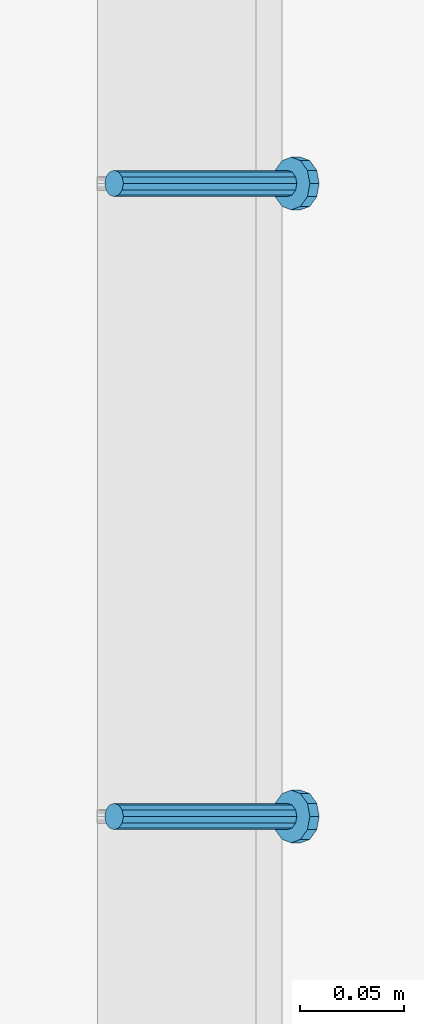
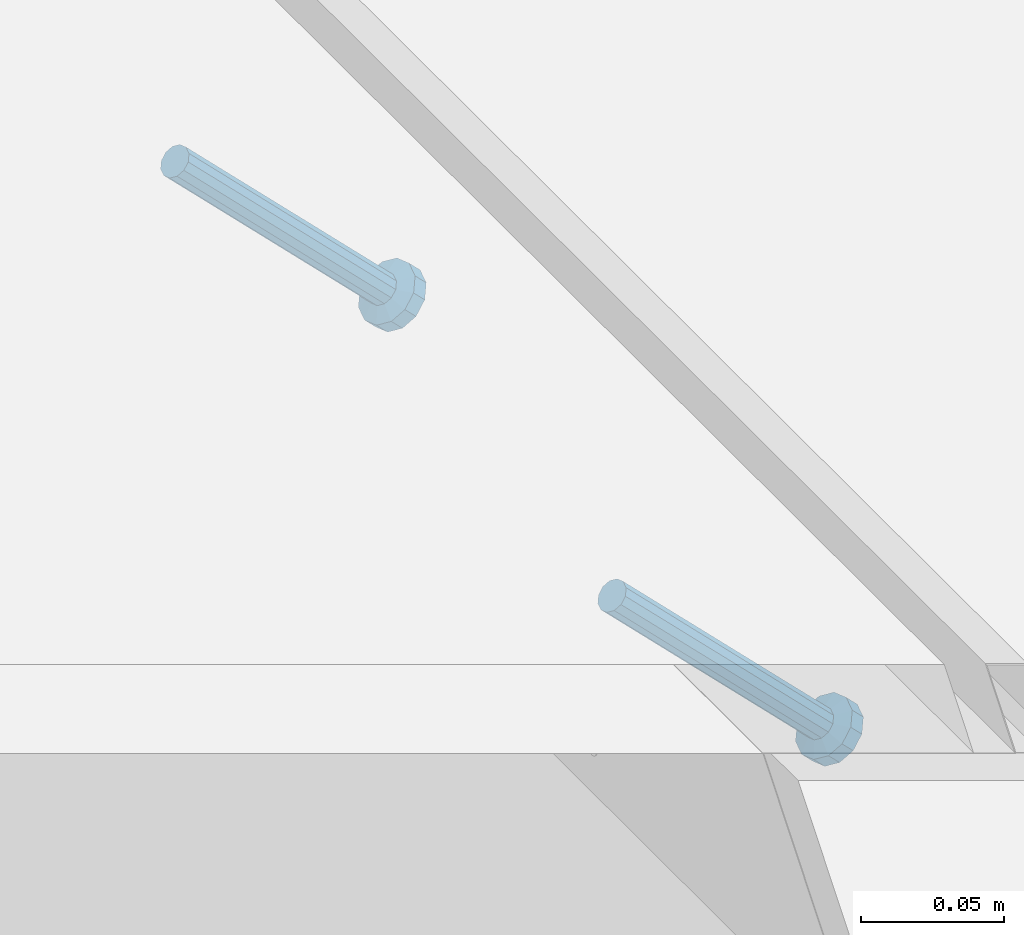
# One storey, part 2287 of 3843: 2 members, 1 element without a shape of its own.
"""IFC2X3 building model written with IfcOpenShell, lengths in millimetres."""

from ifc_helpers import new_model, si_unit, frame, origin_with_axes, place, context, subcontext, project, spatial, faceted_brep, material, type_object, element, aggregate, save


model = new_model("IFC2X3")

# Units and contexts
model_context = context("Model", 3, precision=1e-05, world=origin_with_axes())
body_context = subcontext(model_context, "Body", "Model", "MODEL_VIEW")
ifc_project = project(units=[si_unit("LENGTHUNIT", "METRE", prefix="MILLI"), si_unit("AREAUNIT", "SQUARE_METRE"), si_unit("VOLUMEUNIT", "CUBIC_METRE"), si_unit("MASSUNIT", "GRAM", prefix="KILO"), si_unit("TIMEUNIT", "SECOND"), si_unit("PLANEANGLEUNIT", "RADIAN"), si_unit("SOLIDANGLEUNIT", "STERADIAN"), si_unit("THERMODYNAMICTEMPERATUREUNIT", "DEGREE_CELSIUS"), si_unit("LUMINOUSINTENSITYUNIT", "LUMEN")], contexts=[model_context])

# Site, building, storey
site_placement = place(None, origin_with_axes())
site = spatial("IfcSite", under=ifc_project, at=site_placement, CompositionType="ELEMENT")
building_placement = place(site_placement, origin_with_axes())
building = spatial("IfcBuilding", under=site, at=building_placement, Name="Undefined", CompositionType="ELEMENT")
storey_placement = place(building_placement, origin_with_axes())
storey = spatial("IfcBuildingStorey", under=building, at=storey_placement, Name="Undefined", CompositionType="ELEMENT", Elevation=0.0)

# Assembly, members
assembly_placement = place(storey_placement, origin_with_axes())
assembly = element("IfcElementAssembly", 1, at=assembly_placement, inside=storey, Name="EMBED_ANGLE", AssemblyPlace="NOTDEFINED", PredefinedType="RIGID_FRAME")
ifc_material = material(Name="STEEL/A108")
member_type = type_object("IfcMemberType", PredefinedType="NOTDEFINED")
member_1_placement = place(assembly_placement, frame((66677.3495, 47218.600201416, 30446.6625), z_axis=(0.0, 1.0, 0.0), x_axis=(0.707106781186548, 0.0, -0.707106781186548)))
member_1 = element("IfcMember", 2, at=member_1_placement, type_object=member_type, material=ifc_material, Name="HEADED STUD ANCHOR", context=body_context, shape_type="Brep", body=[
    faceted_brep([(7.27595761418343e-12, -3.18000006675175, 5.5), (0.0, -5.49999999998363, 3.1800000667572), (118.110000000976, -5.49999999999091, 3.1800000667572), (118.110000000983, -3.18000006675175, 5.5), (0.0, -6.3499999046162, 0.0), (118.110000000968, -6.34999990461256, 0.0), (0.0, -5.49999999998363, -3.1800000667572), (118.110000000976, -5.49999999999091, -3.1800000667572), (7.27595761418343e-12, -3.18000006675175, -5.5), (118.110000000983, -3.18000006675175, -5.5), (7.27595761418343e-12, -1.81898940354586e-12, -6.34999990463257), (118.110000000968, -1.81898940354586e-12, -6.34999990463257), (0.0, 3.18000006675175, -5.5), (118.110000000968, 3.18000006674811, -5.5), (7.27595761418343e-12, 5.49999999998363, -3.1800000667572), (118.110000000983, 5.49999999998363, -3.1800000667572), (7.27595761418343e-12, 6.3499999046162, 0.0), (118.110000000976, 6.34999990461256, 0.0), (7.27595761418343e-12, 5.49999999998363, 3.1800000667572), (118.110000000983, 5.49999999998363, 3.1800000667572), (0.0, 3.18000006675175, 5.5), (118.110000000968, 3.18000006674811, 5.5), (7.27595761418343e-12, -1.81898940354586e-12, 6.34999990463257), (118.110000000968, -1.81898940354586e-12, 6.34999990463257), (120.650000000991, -10.9899997710909, 6.34999990463257), (120.650000000998, -6.34000015257152, 10.9899997711182), (120.650000000991, -12.6999998092379, 0.0), (120.650000000991, -10.9899997710909, -6.34999990463257), (120.650000000998, -6.34000015257152, -10.9899997711182), (120.650000000991, -1.81898940354586e-12, -12.6899995803833), (120.650000000991, 6.34000015257152, -10.9899997711182), (120.650000000998, 10.9899997710909, -6.34999990463257), (120.650000000991, 12.6999998092342, 0.0), (120.650000000998, 10.9899997710909, 6.34999990463257), (120.650000000991, 6.34000015257152, 10.9899997711182), (120.650000000991, -1.81898940354586e-12, 12.6899995803833), (127.000000001048, -10.9899997710945, 6.34999990463257), (127.000000001048, -6.34000015257152, 10.9899997711182), (127.000000001048, -12.6999998092342, 0.0), (127.000000001048, -10.9899997710945, -6.34999990463257), (127.000000001048, -6.34000015257152, -10.9899997711182), (127.000000001048, 1.81898940354586e-12, -12.6899995803833), (127.000000001048, 6.34000015256788, -10.9899997711182), (127.000000001048, 10.9899997710909, -6.34999990463257), (127.000000001048, 12.6999998092379, 0.0), (127.000000001048, 10.9899997710909, 6.34999990463257), (127.000000001048, 6.34000015256788, 10.9899997711182), (127.000000001048, 1.81898940354586e-12, 12.6899995803833)], [[[0, 1, 2, 3]], [[1, 4, 5, 2]], [[4, 6, 7, 5]], [[6, 8, 9, 7]], [[8, 10, 11, 9]], [[10, 12, 13, 11]], [[12, 14, 15, 13]], [[14, 16, 17, 15]], [[16, 18, 19, 17]], [[18, 20, 21, 19]], [[20, 22, 23, 21]], [[22, 0, 3, 23]], [[22, 20, 18, 16, 14, 12, 10, 8, 6, 4, 1, 0]], [[3, 2, 24, 25]], [[2, 5, 26, 24]], [[5, 7, 27, 26]], [[7, 9, 28, 27]], [[9, 11, 29, 28]], [[11, 13, 30, 29]], [[13, 15, 31, 30]], [[15, 17, 32, 31]], [[17, 19, 33, 32]], [[19, 21, 34, 33]], [[21, 23, 35, 34]], [[23, 3, 25, 35]], [[25, 24, 36, 37]], [[24, 26, 38, 36]], [[26, 27, 39, 38]], [[27, 28, 40, 39]], [[28, 29, 41, 40]], [[29, 30, 42, 41]], [[30, 31, 43, 42]], [[31, 32, 44, 43]], [[32, 33, 45, 44]], [[33, 34, 46, 45]], [[34, 35, 47, 46]], [[35, 25, 37, 47]], [[38, 39, 40, 41, 42, 43, 44, 45, 46, 47, 37, 36]]]),
])
member_2_placement = place(assembly_placement, frame((66677.3495, 47523.400201416, 30446.6625), z_axis=(0.0, 1.0, 0.0), x_axis=(0.707106781186548, 0.0, -0.707106781186548)))
member_2 = element("IfcMember", 3, at=member_2_placement, type_object=member_type, material=ifc_material, Name="HEADED STUD ANCHOR", context=body_context, shape_type="Brep", body=[
    faceted_brep([(7.27595761418343e-12, -3.18000006675175, 5.5), (0.0, -5.49999999998363, 3.1800000667572), (118.110000000976, -5.49999999999091, 3.1800000667572), (118.110000000983, -3.18000006675175, 5.5), (0.0, -6.3499999046162, 0.0), (118.110000000968, -6.34999990461256, 0.0), (0.0, -5.49999999998363, -3.1800000667572), (118.110000000976, -5.49999999999091, -3.1800000667572), (7.27595761418343e-12, -3.18000006675175, -5.5), (118.110000000983, -3.18000006675175, -5.5), (7.27595761418343e-12, -1.81898940354586e-12, -6.34999990463257), (118.110000000968, -1.81898940354586e-12, -6.34999990463257), (0.0, 3.18000006675175, -5.5), (118.110000000968, 3.18000006674811, -5.5), (7.27595761418343e-12, 5.49999999998363, -3.1800000667572), (118.110000000983, 5.49999999998363, -3.1800000667572), (7.27595761418343e-12, 6.3499999046162, 0.0), (118.110000000976, 6.34999990461256, 0.0), (7.27595761418343e-12, 5.49999999998363, 3.1800000667572), (118.110000000983, 5.49999999998363, 3.1800000667572), (0.0, 3.18000006675175, 5.5), (118.110000000968, 3.18000006674811, 5.5), (7.27595761418343e-12, -1.81898940354586e-12, 6.34999990463257), (118.110000000968, -1.81898940354586e-12, 6.34999990463257), (120.650000000991, -10.9899997710909, 6.34999990463257), (120.650000000998, -6.34000015257152, 10.9899997711182), (120.650000000991, -12.6999998092379, 0.0), (120.650000000991, -10.9899997710909, -6.34999990463257), (120.650000000998, -6.34000015257152, -10.9899997711182), (120.650000000991, -1.81898940354586e-12, -12.6899995803833), (120.650000000991, 6.34000015257152, -10.9899997711182), (120.650000000998, 10.9899997710909, -6.34999990463257), (120.650000000991, 12.6999998092342, 0.0), (120.650000000998, 10.9899997710909, 6.34999990463257), (120.650000000991, 6.34000015257152, 10.9899997711182), (120.650000000991, -1.81898940354586e-12, 12.6899995803833), (127.000000001048, -10.9899997710945, 6.34999990463257), (127.000000001048, -6.34000015257152, 10.9899997711182), (127.000000001048, -12.6999998092342, 0.0), (127.000000001048, -10.9899997710945, -6.34999990463257), (127.000000001048, -6.34000015257152, -10.9899997711182), (127.000000001048, 1.81898940354586e-12, -12.6899995803833), (127.000000001048, 6.34000015256788, -10.9899997711182), (127.000000001048, 10.9899997710909, -6.34999990463257), (127.000000001048, 12.6999998092379, 0.0), (127.000000001048, 10.9899997710909, 6.34999990463257), (127.000000001048, 6.34000015256788, 10.9899997711182), (127.000000001048, 1.81898940354586e-12, 12.6899995803833)], [[[0, 1, 2, 3]], [[1, 4, 5, 2]], [[4, 6, 7, 5]], [[6, 8, 9, 7]], [[8, 10, 11, 9]], [[10, 12, 13, 11]], [[12, 14, 15, 13]], [[14, 16, 17, 15]], [[16, 18, 19, 17]], [[18, 20, 21, 19]], [[20, 22, 23, 21]], [[22, 0, 3, 23]], [[22, 20, 18, 16, 14, 12, 10, 8, 6, 4, 1, 0]], [[3, 2, 24, 25]], [[2, 5, 26, 24]], [[5, 7, 27, 26]], [[7, 9, 28, 27]], [[9, 11, 29, 28]], [[11, 13, 30, 29]], [[13, 15, 31, 30]], [[15, 17, 32, 31]], [[17, 19, 33, 32]], [[19, 21, 34, 33]], [[21, 23, 35, 34]], [[23, 3, 25, 35]], [[25, 24, 36, 37]], [[24, 26, 38, 36]], [[26, 27, 39, 38]], [[27, 28, 40, 39]], [[28, 29, 41, 40]], [[29, 30, 42, 41]], [[30, 31, 43, 42]], [[31, 32, 44, 43]], [[32, 33, 45, 44]], [[33, 34, 46, 45]], [[34, 35, 47, 46]], [[35, 25, 37, 47]], [[38, 39, 40, 41, 42, 43, 44, 45, 46, 47, 37, 36]]]),
])
aggregate(assembly, [member_1, member_2])

save(model, "model.ifc")
